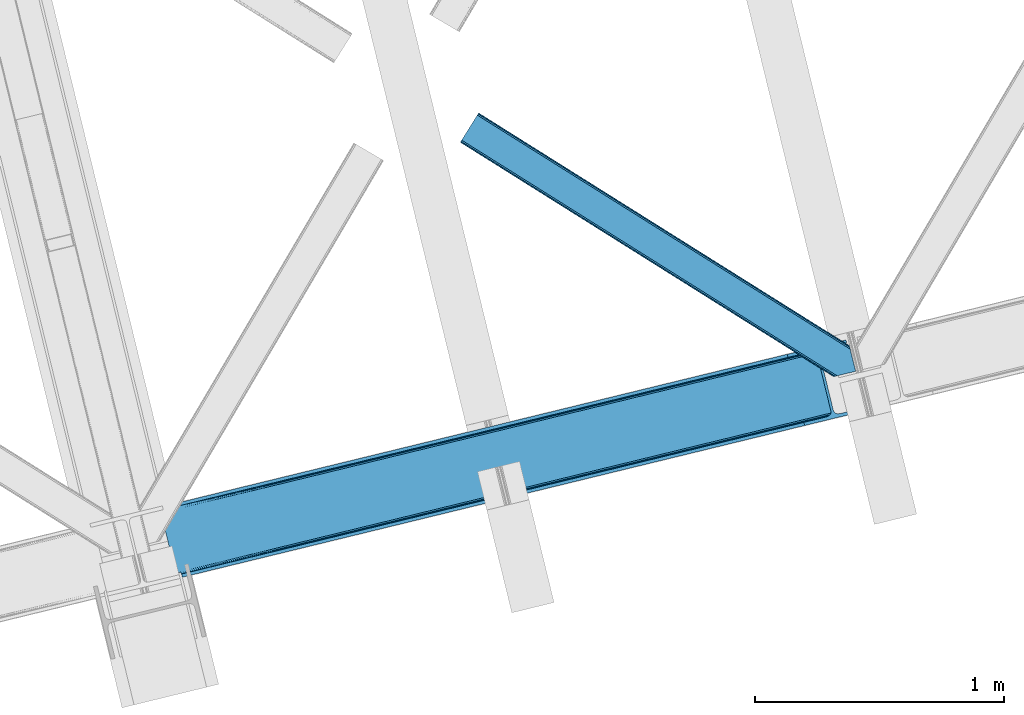
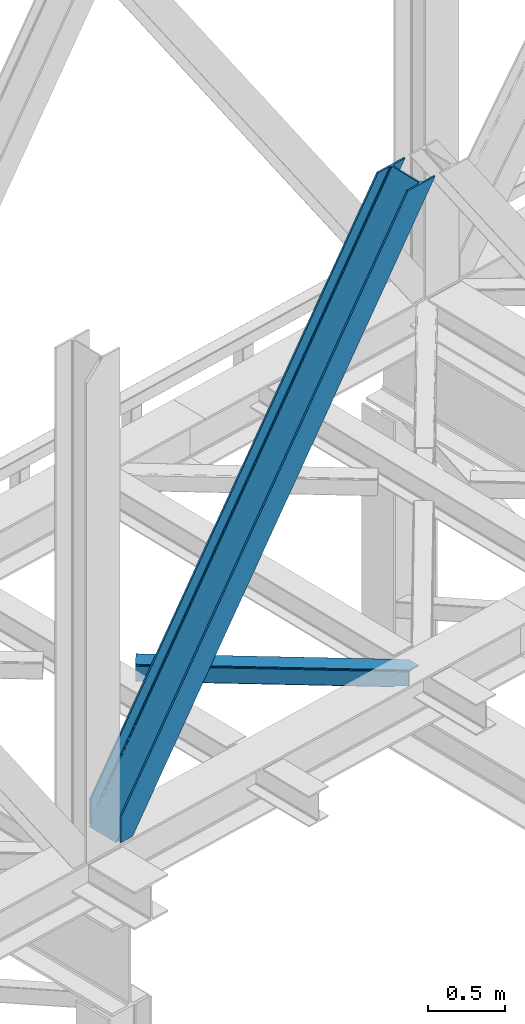
# One storey, part 33 of 93: 2 members.
"""IFC4 building model written with IfcOpenShell, lengths in millimetres."""

from ifc_helpers import new_model, entity, si_unit, converted_unit, derived_unit, direction, frame, origin, place, context, subcontext, project, spatial, triangles, type_object, element, save


model = new_model("IFC4")

# Units and contexts
model_context = context("Model", 3, precision=0.01, world=origin(), true_north=direction((6.12303176911189e-17, 1.0)))
plan_context = context("Plan", 3, precision=0.01, world=origin(), true_north=direction((6.12303176911189e-17, 1.0)))
body_context = subcontext(model_context, "Body", "Model", "MODEL_VIEW")
ifc_project = project(units=[si_unit("LENGTHUNIT", "METRE", prefix="MILLI"), si_unit("AREAUNIT", "SQUARE_METRE"), si_unit("VOLUMEUNIT", "CUBIC_METRE"), converted_unit("PLANEANGLEUNIT", "DEGREE", entity("IfcRatioMeasure", 0.0174532925199433), si_unit("PLANEANGLEUNIT", "RADIAN"), dimensions=[0, 0, 0, 0, 0, 0, 0]), si_unit("MASSUNIT", "GRAM", prefix="KILO"), derived_unit("MASSDENSITYUNIT", [(si_unit("MASSUNIT", "GRAM", prefix="KILO"), 1), (si_unit("LENGTHUNIT", "METRE"), -3)]), derived_unit("MOMENTOFINERTIAUNIT", [(si_unit("LENGTHUNIT", "METRE"), 4)]), si_unit("TIMEUNIT", "SECOND"), si_unit("FREQUENCYUNIT", "HERTZ"), si_unit("THERMODYNAMICTEMPERATUREUNIT", "DEGREE_CELSIUS"), derived_unit("THERMALTRANSMITTANCEUNIT", [(si_unit("MASSUNIT", "GRAM", prefix="KILO"), 1), (si_unit("THERMODYNAMICTEMPERATUREUNIT", "KELVIN"), -1), (si_unit("TIMEUNIT", "SECOND"), -3)]), derived_unit("VOLUMETRICFLOWRATEUNIT", [(si_unit("LENGTHUNIT", "METRE"), 3), (si_unit("TIMEUNIT", "SECOND"), -1)]), derived_unit("MASSFLOWRATEUNIT", [(si_unit("MASSUNIT", "GRAM", prefix="KILO"), 1), (si_unit("TIMEUNIT", "SECOND"), -1)]), derived_unit("ROTATIONALFREQUENCYUNIT", [(si_unit("TIMEUNIT", "SECOND"), -1)]), si_unit("ELECTRICCURRENTUNIT", "AMPERE"), si_unit("ELECTRICVOLTAGEUNIT", "VOLT"), si_unit("POWERUNIT", "WATT"), si_unit("FORCEUNIT", "NEWTON", prefix="KILO"), si_unit("ILLUMINANCEUNIT", "LUX"), si_unit("LUMINOUSFLUXUNIT", "LUMEN"), si_unit("LUMINOUSINTENSITYUNIT", "CANDELA"), derived_unit("USERDEFINED", [(si_unit("MASSUNIT", "GRAM", prefix="KILO"), -1), (si_unit("LENGTHUNIT", "METRE"), -2), (si_unit("TIMEUNIT", "SECOND"), 3), (si_unit("LUMINOUSFLUXUNIT", "LUMEN"), 1)]), derived_unit("LINEARVELOCITYUNIT", [(si_unit("LENGTHUNIT", "METRE"), 1), (si_unit("TIMEUNIT", "SECOND"), -1)]), si_unit("PRESSUREUNIT", "PASCAL"), derived_unit("USERDEFINED", [(si_unit("LENGTHUNIT", "METRE"), -2), (si_unit("MASSUNIT", "GRAM", prefix="KILO"), 1), (si_unit("TIMEUNIT", "SECOND"), -2)]), derived_unit("LINEARFORCEUNIT", [(si_unit("MASSUNIT", "GRAM", prefix="KILO"), 1), (si_unit("LENGTHUNIT", "METRE"), 1), (si_unit("TIMEUNIT", "SECOND"), -2), (si_unit("LENGTHUNIT", "METRE"), -1)]), derived_unit("PLANARFORCEUNIT", [(si_unit("MASSUNIT", "GRAM", prefix="KILO"), 1), (si_unit("LENGTHUNIT", "METRE"), 1), (si_unit("TIMEUNIT", "SECOND"), -2), (si_unit("LENGTHUNIT", "METRE"), -2)])], contexts=[model_context, plan_context])

# Site, building, storey
site_placement = place(None, origin())
site = spatial("IfcSite", under=ifc_project, at=site_placement, CompositionType="ELEMENT")
building_placement = place(site_placement, origin())
building = spatial("IfcBuilding", under=site, at=building_placement, CompositionType="ELEMENT")
storey_placement = place(building_placement, frame((0.0, 0.0, 15900.0)))
storey = spatial("IfcBuildingStorey", under=building, at=storey_placement, CompositionType="ELEMENT", Elevation=15900.0)

# Members
member_type_1 = type_object("IfcMemberType", PredefinedType="BRACE")
member_1_placement = place(storey_placement, frame((-54343.5154907227, 4224.29593276978, 3694.99929199219)))
element("IfcMember", 1, at=member_1_placement, inside=storey, type_object=member_type_1, ObjectType="Steel Vertical Brace", PredefinedType="BRACE", context=body_context, shape_type="Tessellation", body=[
    triangles([(58.5731689453169, 24.841216278076, 0.0), (60.4707275390683, 17.0687255859375, 0.0), (59.1126708984375, 17.8820480346685, 0.781347656247817), (58.97314453125, 16.7036315917967, 1.0697021484375), (71.428198242189, 19.7406555175785, 19.5569458007813), (71.428198242189, 19.7406555175785, 0.0), (499.290454101567, 119.170051574707, 658.75048828125), (75.71630859375, 19.9240745544439, 26.4030395507798), (79.7486206054746, 18.4526527404787, 34.3676696777329), (501.0252319336, 125.602798461914, 656.525042724606), (81.3299194335996, 17.2873168945316, 38.5441589355469), (2694.24484863281, 660.223363494873, 3911.00081176758), (2694.23089599609, 667.310721588135, 3911.00081176758), (2268.1359741211, 563.444677734376, 3278.7231262207), (2268.67082519532, 556.485800170899, 3279.50447387695), (2691.01248779297, 653.425522613526, 3911.00081176758), (2266.94069824219, 550.053053283692, 3281.72759399414), (2685.03145751954, 647.951147460938, 3911.00081176758), (2263.20139160156, 545.125737762452, 3285.05529785156), (2677.21333007813, 644.634780120849, 3911.00081176758), (2258.02961425782, 542.454098510742, 3288.98063964843), (490.379370117189, 111.571096801758, 666.003533935545), (495.555798339847, 114.242736053467, 662.07819213867), (84.4413574218779, 12.619287872315, 63.6403015136711), (83.9111572265683, 13.9000236511229, 51.2480346679658), (82.7484375000058, 15.4260932922361, 45.5251281738274), (500.485729980472, 132.561676025391, 655.74602050781), (942.937792968754, 233.323548889161, 1312.27106323242), (942.398291015626, 240.282426452637, 1311.48971557617), (1384.845703125, 341.044299316406, 1968.01475830078), (1384.31085205078, 348.003176879883, 1967.23341064453), (1826.75826416016, 448.765049743653, 2623.75845336914), (1826.22341308594, 455.723927307129, 2622.97710571289), (941.203015136722, 226.890802001953, 1314.49418334961), (1383.11557617188, 334.611552429199, 1970.23787841797), (1825.02813720703, 442.332302856445, 2625.98389892578), (937.468359375001, 221.963486480713, 1317.82188720703), (1379.37626953125, 329.68423690796, 1973.56790771484), (1821.28883056641, 437.404987335205, 2629.3116027832), (932.291931152344, 219.291847229004, 1321.74955444336), (1374.20449218751, 327.01259765625, 1977.49324951172), (1816.11705322266, 434.733348083496, 2633.23694458008), (84.4413574218779, 12.619287872315, 200.055230712889), (2585.27940673829, 622.225392150879, 3911.00081176758), (1329.12817382813, 574.374824523926, 1967.23341064453), (2639.05286865235, 893.682369232178, 3911.00081176758), (2212.95329589844, 789.816034698487, 3278.7231262207), (1771.04073486329, 682.095865631104, 2622.97710571289), (887.21561279297, 466.65407409668, 1311.48971557617), (445.307702636725, 358.933323669434, 655.74602050781), (3.3951416015625, 251.212863922119, 0.0), (2588.35828857422, 609.595058441162, 3911.00081176758), (84.7204101562529, 11.6585906982427, 200.120343017577), (87.5620971679746, 0.0, 200.120343017577), (87.5620971679746, 0.0, 0.0), (84.7204101562529, 11.6585906982427, 0.0), (72.8095092773438, 19.9851173400884, 0.0), (75.71630859375, 19.9240745544439, 3.35328369140552), (79.7486206054746, 18.4526527404787, 5.67639770507594), (77.6138671875015, 19.4549171447752, 4.89272460937354), (81.3299194335996, 17.2873168945316, 5.12991943359157), (82.9112182617246, 15.5499229431152, 2.42078247070094), (83.5158325195371, 14.6316650390627, 0.0), (189.179150390628, 24.769999694824, 0.0), (2824.83687744141, 667.239795684814, 3911.00081176758), (85.7296508789077, 14.7063697814947, 0.0), (94.1709960937515, 14.9909454345707, 0.0), (186.100268554692, 37.400333404541, 0.0), (2821.75799560547, 679.8698387146, 3911.00081176758), (1408.54193115234, 335.383016967774, 1950.37164916992), (2299.97124023438, 552.678183746338, 3273.1420715332), (1854.25891113281, 444.030745697021, 2611.75686035156), (2729.82872314454, 657.460741424561, 3911.00081176758), (962.829602050784, 226.735869598388, 1288.98643798828), (517.117272949225, 118.088140869141, 627.598901367186), (501.20661621094, 125.647853851318, 637.077392578125), (72.1583862304688, 21.124001312256, 0.0), (505.704016113283, 120.733618927002, 634.854272460936), (498.481201171875, 132.073624420166, 637.858740234373), (511.294372558594, 118.07912979126, 631.526568603513), (2721.35947265625, 656.806130218506, 3911.00081176758), (2294.14833984376, 552.668881988526, 3277.06973876953), (2713.53204345703, 658.914141082764, 3911.00081176758), (2288.56263427735, 555.323371124267, 3280.39744262695), (2707.53240966797, 663.46328201294, 3911.00081176758), (2284.065234375, 560.237606048584, 3282.62056274414), (2704.2814453125, 669.760572052002, 3911.00081176758), (2281.33981933594, 566.663376617432, 3283.40191040039), (68.6237182617188, 27.2910667419437, 0.0), (957.006701660161, 226.726567840577, 1292.91177978515), (1402.71903076172, 335.373715209961, 1954.2969909668), (1848.43135986329, 444.021443939209, 2615.68220214844), (951.420996093751, 229.381056976318, 1296.23948364258), (1397.13332519532, 338.028495025635, 1957.62469482422), (1842.84565429688, 446.675933074951, 2619.01223144531), (946.923596191409, 234.295291900635, 1298.46260375976), (1392.63592529297, 342.942729949951, 1959.85014038086), (1838.34825439454, 451.590167999268, 2621.2353515625), (944.198181152344, 240.721062469483, 1299.24395141601), (1389.91051025391, 349.368209838867, 1960.63148803711), (1835.62283935547, 458.015938568115, 2622.01669921875), (1780.44481201172, 684.387586212159, 2622.01669921875), (1334.72783203125, 575.73985748291, 1960.63148803711), (2649.10341796876, 896.132219696045, 3911.00081176758), (2226.15714111328, 793.035024261475, 3283.40191040039), (889.015502929688, 467.092710113526, 1299.24395141601), (443.303173828128, 358.445272064209, 637.858740234373), (13.4456909179717, 253.662714385987, 0.0), (1.49758300781832, 258.985063934327, 0.0), (12.4597045898481, 261.657284545899, 0.0), (13.7433471679688, 260.764025115967, 0.0), (13.7991577148496, 262.075282287597, 0.0), (0.0, 258.620260620118, 1.0697021484375), (12.4597045898481, 261.657284545899, 19.5569458007813), (0.669726562504366, 257.638343811035, 0.781347656247817), (438.084887695317, 370.273329162598, 658.75048828125), (432.499182128908, 372.928108978272, 662.07819213867), (20.8545410156294, 272.585105895996, 51.2480346679658), (20.7243164062529, 270.661095428467, 44.4996093749978), (442.582287597659, 365.359094238282, 656.525042724606), (16.3524902343779, 263.467348480225, 26.4030395507798), (19.8220458984433, 268.183339691162, 38.2720825195283), (19.254638671875, 266.629364776612, 34.3676696777329), (426.671630859375, 372.918807220459, 666.003533935545), (20.733618164064, 273.966707611085, 63.6403015136711), (2621.9748413086, 906.63622970581, 3911.00081176758), (2613.50559082031, 905.982199859619, 3911.00081176758), (2200.14477539063, 803.810529327393, 3285.05529785156), (2194.321875, 803.801808929444, 3288.98063964843), (2629.80227050782, 904.528800201416, 3911.00081176758), (2205.73048095703, 801.15604019165, 3281.72759399414), (2635.80190429688, 899.97965927124, 3911.00081176758), (2210.22788085938, 796.242386627197, 3279.50447387695), (874.407092285161, 480.648568725586, 1317.82188720703), (868.584191894537, 480.639266967773, 1321.74955444336), (1316.31965332032, 588.369319152832, 1973.56790771484), (1310.49675292969, 588.360308074952, 1977.49324951172), (1758.23221435547, 696.09036026001, 2629.3116027832), (1752.40931396485, 696.081058502197, 2633.23694458008), (879.992797851563, 477.994079589844, 1314.49418334961), (1321.90535888672, 585.71483001709, 1970.23787841797), (1763.81791992188, 693.435289764405, 2625.98389892578), (884.490197753912, 473.079844665527, 1312.27106323242), (1326.40275878907, 580.800595092774, 1968.01475830078), (1768.31531982422, 688.521054840088, 2623.75845336914), (2521.57631835938, 883.57310256958, 3911.00081176758), (20.733618164064, 273.966707611085, 200.055230712889), (16.3524902343779, 263.467348480225, 3.35328369140552), (19.254638671875, 266.629364776612, 5.67639770507594), (17.8221679687558, 264.760583496094, 4.89505004882813), (20.1197021484404, 268.390594482422, 5.12991943359157), (20.7243164062529, 270.661095428467, 2.42078247070094), (20.5429321289121, 274.94920578003, 0.0), (20.8405883789092, 271.754633331299, 0.0), (20.5429321289121, 274.94920578003, 200.120343017577), (22.8404663085967, 272.707191467285, 0.0), (448.233105468753, 376.764212036133, 631.526568603513), (444.498449707033, 371.836896514893, 634.854272460936), (30.4632568359375, 276.338655853272, 0.0), (442.763671875, 365.404149627686, 637.077392578125), (2649.08946533204, 903.219577789307, 3911.00081176758), (2225.62229003906, 799.993901824952, 3282.62056274414), (2652.32182617188, 910.017418670654, 3911.00081176758), (2227.35241699219, 806.426648712159, 3280.39744262695), (2658.30285644531, 915.491503143311, 3911.00081176758), (2231.09172363282, 811.353673553467, 3277.06973876953), (2666.12098388672, 918.808161163331, 3911.00081176758), (2236.26350097657, 814.025603485107, 3273.1420715332), (453.409533691411, 379.435851287842, 627.598901367186), (888.480651855469, 474.051587677002, 1298.46260375976), (1334.19298095704, 582.699025726319, 1959.85014038086), (1779.9053100586, 691.346463775635, 2621.2353515625), (890.2107788086, 480.484334564209, 1296.23948364258), (1335.92310791016, 589.131772613526, 1957.62469482422), (1781.64008789063, 697.779210662842, 2619.01223144531), (893.950085449222, 485.41165008545, 1292.91177978515), (1339.66241455078, 594.059088134766, 1954.2969909668), (1785.37474365235, 702.706235504151, 2615.68220214844), (899.12186279297, 488.083289337158, 1288.98643798828), (1344.83419189454, 596.730727386474, 1950.37164916992), (1790.55117187501, 705.378165435791, 2611.75686035156), (2518.49743652344, 896.203145599366, 3911.00081176758), (17.7012451171904, 286.607796478272, 200.120343017577), (17.7012451171904, 286.607796478272, 0.0), (2754.97602539063, 953.847301483154, 3911.00081176758), (2758.05490722656, 941.217258453369, 3911.00081176758), (119.318298339844, 311.378086853028, 0.0), (122.397180175787, 298.747753143311, 0.0)], [[1, 2, 3], [4, 3, 2], [5, 4, 6], [2, 6, 4], [7, 8, 9], [10, 3, 5], [5, 7, 10], [5, 8, 7], [3, 4, 5], [9, 11, 7], [12, 13, 14], [14, 15, 12], [16, 12, 15], [15, 17, 16], [18, 16, 17], [17, 19, 18], [20, 18, 19], [19, 21, 20], [22, 23, 24], [25, 24, 23], [25, 7, 26], [25, 23, 7], [11, 26, 7], [10, 27, 3], [1, 3, 27], [28, 29, 27], [27, 10, 28], [30, 31, 29], [29, 28, 30], [32, 33, 31], [31, 30, 32], [15, 14, 32], [33, 32, 14], [34, 28, 7], [10, 7, 28], [35, 30, 34], [28, 34, 30], [36, 32, 35], [30, 35, 32], [17, 15, 36], [32, 36, 15], [37, 34, 23], [7, 23, 34], [38, 35, 37], [34, 37, 35], [39, 36, 35], [35, 38, 39], [19, 17, 36], [36, 39, 19], [40, 37, 23], [23, 22, 40], [41, 38, 37], [37, 40, 41], [42, 39, 38], [38, 41, 42], [21, 19, 42], [39, 42, 19], [41, 43, 44], [44, 21, 42], [21, 44, 20], [42, 41, 44], [43, 41, 40], [40, 22, 43], [24, 43, 22], [33, 45, 31], [13, 46, 47], [48, 14, 47], [45, 33, 48], [47, 14, 13], [48, 33, 14], [31, 49, 29], [49, 50, 27], [49, 31, 45], [51, 1, 50], [49, 27, 29], [50, 1, 27], [52, 53, 54], [52, 44, 53], [43, 53, 44], [55, 54, 53], [53, 56, 55], [5, 6, 57], [58, 8, 5], [59, 9, 8], [8, 58, 60], [61, 26, 11], [61, 11, 9], [9, 59, 61], [56, 26, 62], [56, 25, 26], [56, 53, 24], [43, 24, 53], [24, 25, 56], [62, 63, 56], [61, 62, 26], [8, 60, 59], [57, 58, 5], [52, 64, 65], [64, 52, 54], [55, 64, 54], [66, 67, 56], [64, 67, 68], [67, 64, 55], [55, 56, 67], [56, 63, 66], [69, 65, 64], [64, 68, 69], [70, 69, 68], [71, 69, 72], [71, 73, 69], [70, 72, 69], [68, 74, 70], [75, 74, 68], [68, 67, 75], [76, 60, 58], [76, 59, 60], [58, 77, 76], [58, 57, 77], [76, 78, 61], [61, 59, 76], [79, 76, 77], [80, 75, 67], [80, 62, 61], [80, 66, 62], [66, 63, 62], [61, 78, 80], [67, 66, 80], [81, 73, 71], [71, 82, 81], [83, 81, 82], [82, 84, 83], [85, 83, 84], [84, 86, 85], [87, 85, 86], [86, 88, 87], [77, 89, 79], [90, 74, 75], [75, 80, 90], [91, 70, 90], [74, 90, 70], [92, 72, 91], [70, 91, 72], [82, 71, 92], [72, 92, 71], [93, 90, 78], [80, 78, 90], [94, 91, 93], [90, 93, 91], [95, 92, 94], [91, 94, 92], [84, 82, 95], [92, 95, 82], [96, 93, 78], [78, 76, 96], [97, 94, 93], [93, 96, 97], [98, 95, 94], [94, 97, 98], [86, 84, 95], [95, 98, 86], [99, 96, 79], [76, 79, 96], [100, 97, 96], [96, 99, 100], [101, 98, 100], [97, 100, 98], [88, 86, 101], [98, 101, 86], [102, 100, 103], [104, 87, 88], [101, 105, 88], [100, 102, 101], [88, 105, 104], [101, 102, 105], [103, 99, 106], [99, 79, 107], [99, 103, 100], [89, 108, 79], [99, 107, 106], [79, 108, 107], [108, 109, 110], [51, 108, 89], [108, 51, 109], [89, 1, 51], [2, 89, 6], [89, 2, 1], [77, 6, 89], [108, 110, 111], [112, 111, 110], [57, 6, 77], [113, 114, 110], [110, 109, 113], [109, 51, 115], [115, 113, 109], [116, 117, 118], [118, 119, 116], [120, 121, 114], [114, 115, 120], [114, 113, 115], [120, 116, 122], [122, 123, 120], [123, 121, 120], [119, 122, 116], [117, 124, 125], [125, 118, 117], [126, 127, 128], [129, 128, 127], [130, 126, 131], [128, 131, 126], [132, 130, 133], [131, 133, 130], [46, 132, 47], [133, 47, 132], [134, 135, 117], [124, 117, 135], [136, 137, 134], [135, 134, 137], [138, 139, 136], [137, 136, 139], [128, 129, 139], [139, 138, 128], [140, 134, 117], [117, 116, 140], [141, 136, 134], [134, 140, 141], [142, 138, 141], [136, 141, 138], [131, 128, 142], [138, 142, 128], [143, 140, 116], [116, 120, 143], [144, 141, 140], [140, 143, 144], [145, 142, 141], [141, 144, 145], [133, 131, 142], [142, 145, 133], [50, 120, 115], [115, 51, 50], [49, 143, 50], [120, 50, 143], [45, 144, 49], [143, 49, 144], [48, 145, 45], [144, 45, 145], [47, 133, 145], [145, 48, 47], [146, 147, 137], [137, 139, 146], [139, 129, 146], [127, 146, 129], [135, 137, 147], [147, 125, 124], [124, 135, 147], [114, 148, 112], [112, 110, 114], [149, 150, 121], [121, 123, 149], [151, 149, 123], [123, 122, 151], [119, 152, 151], [153, 118, 125], [153, 154, 152], [152, 119, 153], [119, 118, 153], [155, 153, 125], [125, 147, 155], [122, 119, 151], [150, 148, 121], [114, 121, 148], [156, 157, 152], [157, 158, 151], [151, 152, 157], [157, 156, 159], [107, 108, 111], [160, 149, 151], [160, 111, 148], [148, 150, 160], [150, 149, 160], [111, 112, 148], [151, 158, 160], [111, 160, 107], [161, 104, 162], [105, 162, 104], [163, 161, 164], [162, 164, 161], [165, 163, 166], [164, 166, 163], [167, 165, 168], [166, 168, 165], [159, 169, 157], [152, 154, 156], [170, 106, 107], [107, 160, 170], [171, 103, 170], [106, 170, 103], [172, 102, 103], [103, 171, 172], [162, 105, 102], [102, 172, 162], [173, 170, 160], [160, 158, 173], [174, 171, 173], [170, 173, 171], [175, 172, 174], [171, 174, 172], [164, 162, 172], [172, 175, 164], [176, 173, 157], [158, 157, 173], [177, 174, 173], [173, 176, 177], [178, 175, 174], [174, 177, 178], [166, 164, 178], [175, 178, 164], [179, 176, 169], [157, 169, 176], [180, 177, 176], [176, 179, 180], [181, 178, 177], [177, 180, 181], [168, 166, 178], [178, 181, 168], [182, 155, 146], [155, 182, 183], [155, 147, 146], [153, 155, 184], [183, 184, 155], [46, 13, 104], [16, 18, 81], [20, 52, 65], [44, 52, 20], [18, 20, 73], [13, 12, 85], [12, 16, 83], [130, 165, 126], [182, 127, 185], [127, 126, 167], [182, 146, 127], [130, 132, 163], [132, 46, 161], [104, 13, 87], [73, 81, 18], [85, 12, 83], [81, 83, 16], [85, 87, 13], [65, 73, 20], [65, 69, 73], [167, 126, 165], [163, 132, 161], [104, 161, 46], [163, 165, 130], [167, 185, 127], [185, 167, 186], [159, 156, 153], [187, 159, 184], [159, 187, 188], [154, 153, 156], [153, 184, 159], [182, 187, 183], [182, 185, 187], [187, 184, 183], [186, 180, 188], [181, 186, 168], [186, 181, 180], [186, 167, 168], [179, 188, 180], [159, 188, 169], [179, 169, 188], [185, 186, 188], [188, 187, 185]]),
])
member_type_2 = type_object("IfcMemberType", PredefinedType="BRACE")
member_2_placement = place(storey_placement, frame((-53139.2029541016, 5030.29760742188, 3511.0000579834)))
element("IfcMember", 2, at=member_2_placement, inside=storey, type_object=member_type_2, ObjectType="Steel Horizontal Brace", PredefinedType="BRACE", context=body_context, shape_type="Tessellation", body=[
    triangles([(9.3017578125, 956.602656555176, 0.0), (65.1262573242202, 1045.53560028076, 0.0), (1381.50637207031, 219.293591308594, 0.0), (1417.18326416016, 72.9304321289064, 0.0), (1422.67595214844, 50.3934356689451, 10.8028289794929), (1423.12708740235, 48.5365722656252, 17.5000946044929), (0.0, 941.780305480957, 17.5000946044929), (0.706933593748545, 942.908724975586, 10.8028289794929), (1421.3876586914, 55.6814849853517, 5.12526855468968), (2.72541503906541, 946.121900939942, 5.12526855468968), (1419.45754394531, 63.5955368041996, 1.33247680664135), (5.74383544921875, 950.930328369141, 1.33247680664135), (68.6841796875015, 1051.2079284668, 1.33247680664135), (71.7026000976548, 1056.01693725586, 5.12526855468968), (1377.31127929688, 236.497773742676, 5.17061462402489), (73.7210815429717, 1059.22953186035, 10.8028289794929), (1382.10633544922, 238.005821228027, 10.8028289794929), (1383.91087646485, 238.445910644531, 17.5000946044929), (74.4280151367202, 1060.35795135498, 17.5000946044929), (1379.22744140625, 228.628486633301, 1.33247680664135), (1377.23221435547, 236.818684387207, 17.5198608398459), (1383.91087646485, 238.445910644531, 18.5197998046897), (1378.20424804687, 237.055297851563, 18.5197998046897), (1379.51114501953, 231.698648071289, 18.5197998046897), (1563.91384277344, 125.462690734864, 18.5197998046897), (1566.65321044922, 114.236631774903, 18.5197998046897), (1563.91384277344, 125.462690734864, 122.500662231447), (74.4280151367202, 1060.35795135498, 122.500662231447), (1564.36962890625, 123.605827331543, 129.197927856447), (73.7210815429717, 1059.22953186035, 129.197927856447), (1565.65792236328, 118.317778015137, 134.874325561526), (71.7026000976548, 1056.01693725586, 134.874325561526), (1567.58803710937, 110.403726196289, 138.667117309571), (68.6841796875015, 1051.2079284668, 138.667117309571), (1569.86231689453, 101.068830871583, 139.999594116212), (65.1262573242202, 1045.53560028076, 139.999594116212), (67.9818969726548, 1050.08764801025, 12.1260040283232), (1379.67857666016, 226.784994506836, 12.1260040283232), (1378.43214111328, 231.905612182617, 17.5198608398459), (70.0003784179717, 1053.30082397461, 17.8035644531265), (1566.29509277344, 115.705146789551, 24.4996673583992), (70.7073120117202, 1054.42924346924, 24.4996673583992), (1381.60869140625, 218.870942687989, 8.3320495605476), (64.9634765625015, 1045.27922058105, 8.3320495605476), (1383.88297119141, 209.536047363282, 6.99957275390625), (61.400903320311, 1039.60689239502, 6.99957275390625), (13.0271118164092, 962.531364440918, 6.99957275390625), (1414.80201416016, 82.6879760742186, 6.99957275390625), (1419.01105957032, 65.4390289306639, 12.1260040283232), (1420.25749511719, 60.3184112548834, 17.5198608398459), (1417.08094482422, 73.3530807495117, 8.3320495605476), (1566.29509277344, 115.705146789551, 115.501089477541), (70.7073120117202, 1054.42924346924, 115.501089477541), (1569.96463623047, 100.646182250976, 131.667544555665), (1572.23891601562, 91.3112869262695, 133.000021362306), (61.400903320311, 1039.60689239502, 133.000021362306), (64.9634765625015, 1045.27922058105, 131.667544555665), (1568.03452148438, 108.560234069824, 127.87475280762), (67.9818969726548, 1050.08764801025, 127.87475280762), (1566.74622802735, 113.848283386231, 122.196029663086), (70.0003784179717, 1053.30082397461, 122.196029663086), (1589.22392578125, 21.6376327514654, 133.000021362306), (1589.22392578125, 21.6376327514654, 139.999594116212), (9.3017578125, 956.602656555176, 139.999594116212), (1524.16743164063, 5.77987976074201, 139.999594116212), (1515.09356689453, 3.56780548095685, 138.667117309571), (5.74383544921875, 950.930328369141, 138.667117309571), (1507.4010131836, 1.69291992187482, 134.874325561526), (2.72541503906541, 946.121900939942, 134.874325561526), (1502.26179199219, 0.440089416503724, 129.197927856447), (0.706933593748545, 942.908724975586, 129.197927856447), (1500.45725097656, 0.0, 122.500662231447), (0.0, 941.780305480957, 122.500662231447), (1424.34561767578, 47.7738281250004, 18.5197998046897), (1500.45725097656, 0.0, 18.5197998046897), (1421.60625, 58.9998870849613, 18.5197998046897), (1511.36821289063, 2.65972137451172, 18.5197998046897), (3.720703125, 947.7090133667, 24.4996673583992), (1509.9403930664, 2.31206817626935, 24.4996673583992), (4.43228759765771, 948.837432861328, 17.8035644531265), (1420.9318725586, 59.6591491699219, 18.0198303222678), (6.44611816406541, 952.050608825683, 12.1260040283232), (9.46453857421875, 956.859036254883, 8.3320495605476), (6.44611816406541, 952.050608825683, 127.87475280762), (13.0271118164092, 962.531364440918, 133.000021362306), (9.46453857421875, 956.859036254883, 131.667544555665), (3.720703125, 947.7090133667, 115.501089477541), (4.43228759765771, 948.837432861328, 122.196029663086), (1524.57670898438, 5.87987365722711, 131.667544555665), (1516.88880615235, 4.00498809814508, 127.87475280762), (1511.74493408203, 2.75215759277398, 122.196029663086), (1533.65057373047, 8.09194793701226, 133.000021362306), (1509.9403930664, 2.31206817626935, 115.501089477541)], [[1, 2, 3], [3, 4, 1], [5, 6, 7], [7, 8, 5], [9, 5, 8], [8, 10, 9], [11, 9, 10], [10, 12, 11], [4, 11, 12], [12, 1, 4], [13, 14, 15], [16, 17, 15], [15, 14, 16], [18, 17, 19], [16, 19, 17], [20, 3, 2], [2, 13, 20], [15, 20, 13], [18, 21, 17], [18, 22, 23], [17, 21, 15], [21, 18, 23], [24, 22, 25], [22, 24, 23], [25, 26, 24], [25, 22, 27], [19, 22, 18], [22, 28, 27], [19, 28, 22], [29, 27, 30], [28, 30, 27], [31, 29, 32], [30, 32, 29], [33, 31, 34], [32, 34, 31], [35, 33, 36], [34, 36, 33], [37, 38, 39], [39, 40, 37], [24, 41, 42], [24, 26, 41], [42, 40, 39], [43, 38, 44], [37, 44, 38], [45, 43, 46], [44, 46, 43], [46, 47, 45], [48, 45, 47], [3, 48, 4], [43, 20, 38], [39, 15, 21], [15, 39, 38], [38, 20, 15], [43, 3, 20], [3, 45, 48], [43, 45, 3], [9, 49, 50], [50, 5, 9], [6, 5, 50], [49, 11, 51], [51, 4, 48], [4, 51, 11], [49, 9, 11], [41, 52, 53], [53, 42, 41], [54, 55, 56], [56, 57, 54], [58, 54, 57], [57, 59, 58], [60, 58, 59], [59, 61, 60], [52, 60, 61], [61, 53, 52], [58, 31, 33], [58, 33, 54], [55, 54, 35], [60, 31, 58], [62, 55, 63], [35, 63, 55], [54, 33, 35], [29, 31, 60], [25, 27, 52], [41, 25, 52], [25, 41, 26], [29, 60, 27], [60, 52, 27], [64, 35, 36], [35, 64, 65], [63, 35, 65], [66, 65, 64], [64, 67, 66], [68, 66, 67], [67, 69, 68], [70, 68, 69], [69, 71, 70], [72, 70, 71], [71, 73, 72], [74, 72, 6], [74, 75, 72], [73, 6, 72], [73, 7, 6], [74, 76, 77], [77, 75, 74], [78, 79, 76], [76, 80, 78], [76, 81, 80], [79, 77, 76], [50, 82, 80], [50, 49, 82], [51, 48, 83], [47, 83, 48], [49, 51, 82], [83, 82, 51], [16, 37, 40], [42, 28, 19], [16, 40, 19], [16, 14, 37], [40, 42, 19], [37, 14, 13], [46, 2, 1], [2, 44, 13], [44, 2, 46], [44, 37, 13], [30, 59, 32], [53, 28, 42], [28, 61, 30], [61, 28, 53], [30, 61, 59], [36, 56, 64], [34, 32, 59], [59, 57, 34], [57, 56, 36], [36, 34, 57], [82, 12, 10], [1, 47, 46], [1, 83, 47], [83, 1, 12], [82, 83, 12], [78, 7, 73], [8, 80, 82], [10, 8, 82], [80, 8, 7], [78, 80, 7], [67, 84, 69], [64, 56, 85], [85, 86, 64], [86, 84, 67], [67, 64, 86], [71, 69, 84], [73, 87, 78], [88, 73, 71], [73, 88, 87], [88, 71, 84], [89, 65, 66], [90, 66, 68], [91, 68, 70], [92, 63, 65], [89, 66, 90], [62, 63, 92], [89, 92, 65], [91, 90, 68], [72, 93, 91], [93, 72, 75], [79, 75, 77], [75, 79, 93], [72, 91, 70], [85, 55, 92], [85, 56, 55], [55, 62, 92], [91, 93, 88], [87, 88, 93], [90, 91, 84], [88, 84, 91], [89, 90, 86], [84, 86, 90], [92, 89, 85], [86, 85, 89], [93, 79, 78], [78, 87, 93]]),
])

save(model, "model.ifc")
